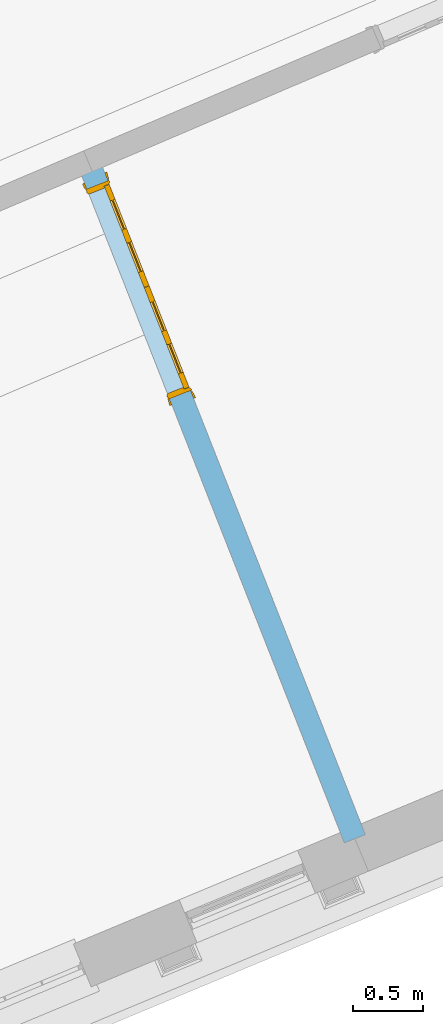
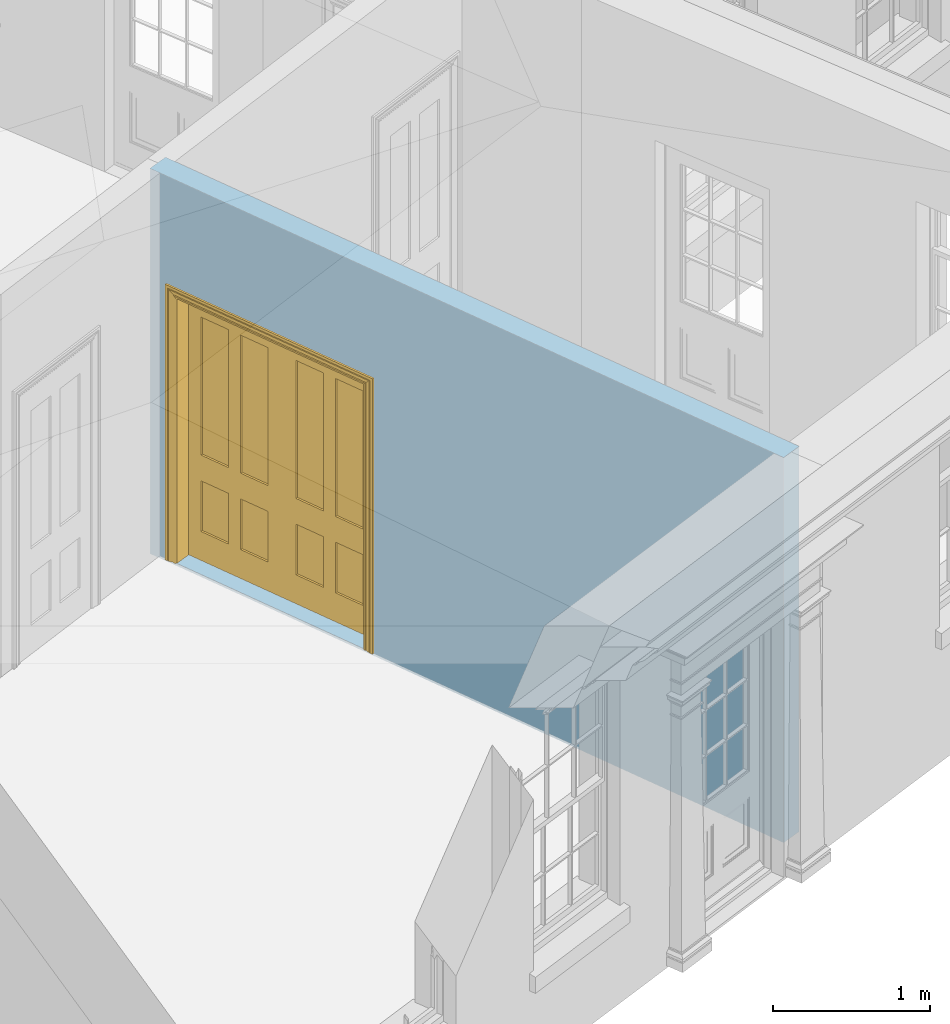
# One storey, part 6 of 19: 1 door, 1 opening, plus 1 element that does not belong to this part.
"""IFC2X3 building model written with IfcOpenShell, lengths in metres."""

from ifc_helpers import new_model, si_unit, frame, origin, place, context, subcontext, project, spatial, polyline, outline, extrude, faceted_brep, material, layer, layer_set, layer_usage, element, fill, save


model = new_model("IFC2X3")

# Units and contexts
model_context = context("Model", 3, world=origin())
body_context = subcontext(model_context, "Body", "Model", "MODEL_VIEW")
ifc_project = project(units=[si_unit("PLANEANGLEUNIT", "RADIAN"), si_unit("MASSUNIT", "GRAM", prefix="KILO"), si_unit("FORCEUNIT", "NEWTON", prefix="KILO"), si_unit("LENGTHUNIT", "METRE")], contexts=[model_context])

# Site, building, storey
site_placement = place(None, origin())
site = spatial("IfcSite", under=ifc_project, at=site_placement, CompositionType="ELEMENT")
building_placement = place(None, origin())
building = spatial("IfcBuilding", under=site, at=building_placement, Name="Building plot-0", CompositionType="ELEMENT")
storey_placement = place(None, origin())
storey = spatial("IfcBuildingStorey", under=building, at=storey_placement, Name="Floor 0", CompositionType="ELEMENT", Elevation=0.0)

# Wall, opening, door
ifc_material = material(Name="Masonry")
ifc_layer = layer(ifc_material, 0.16, ventilated=False)
ifc_layer_set = layer_set([ifc_layer], Name="My Wall")
ifc_layer_usage = layer_usage(ifc_layer_set, "AXIS2", "NEGATIVE", 0.08)
wall_placement = place(storey_placement, origin())
wall = element("IfcWallStandardCase", 1, at=wall_placement, inside=storey, material=ifc_layer_usage, Name="interior", context=body_context, shape_type="SweptSolid", body=[
    extrude(outline(polyline([(19.3861020160304, 27.3528276448736), (19.2372305853062, 27.294199178118), (21.1300433248854, 22.487903598045), (21.2789147556096, 22.5465320648006), (19.3861020160304, 27.3528276448736)])), origin(), (0.0, 0.0, 1.0), 3.0),
])
opening_placement = place(storey_placement, frame((0.0, 0.0, 0.02)))
opening = element("IfcOpeningElement", 2, at=opening_placement, cuts=wall, Name="Opening", ObjectType="Opening", context=body_context, shape_type="SweptSolid", body=[
    extrude(outline(polyline([(19.3031876104063, 27.1267188185532), (19.889472277963, 25.6380045113109), (20.0383437086872, 25.6966329780665), (19.4520590411305, 27.1853472853089), (19.3031876104063, 27.1267188185532)])), origin(), (0.0, 0.0, 1.0), 2.1),
])
door_placement = place(storey_placement, frame((19.3776233257684, 27.156033051931, 0.02), z_axis=(0.0, 0.0, 1.0), x_axis=(0.586284667556651, -1.48871430724233, 0.0)))
door = element("IfcDoor", 3, at=door_placement, inside=storey, Name="kitchen living inside door", OverallHeight=2.1, OverallWidth=1.6, context=body_context, shape_type="Brep", held_by="IfcProductRepresentation", body=[
    faceted_brep([(0.14, 0.057, 1.895), (0.14, 0.057, 0.82), (0.363, 0.057, 0.82), (0.363, 0.057, 1.895), (0.14, 0.042, 1.895), (0.14, 0.042, 0.82), (0.363, 0.042, 0.82), (0.363, 0.042, 1.895), (0.027, 0.042, 1.895), (0.027, 0.042, 0.82), (0.363, 0.042, 0.62), (0.14, 0.042, 0.62), (0.463, 0.042, 0.82), (0.463, 0.042, 1.895), (0.363, 0.042, 2.073), (0.14, 0.042, 2.073), (0.027, 0.042, 2.073), (0.027, 0.08, 1.895), (0.027, 0.08, 0.82), (0.027, 0.042, 0.62), (0.463, 0.042, 0.62), (0.14, 0.057, 0.62), (0.363, 0.057, 0.62), (0.463, 0.057, 0.82), (0.463, 0.057, 1.895), (0.463, 0.042, 2.073), (0.14, 0.08, 2.073), (0.363, 0.08, 2.073), (0.027, 0.08, 2.073), (0.14, 0.08, 1.895), (0.14, 0.08, 0.82), (0.027, 0.08, 0.62), (0.027, 0.042, 0.225), (0.14, 0.042, 0.225), (0.363, 0.042, 0.225), (0.463, 0.042, 0.225), (0.686, 0.042, 0.62), (0.686, 0.042, 0.82), (0.14, 0.057, 0.225), (0.363, 0.057, 0.225), (0.686, 0.057, 0.82), (0.686, 0.057, 1.895), (0.686, 0.042, 1.895), (0.686, 0.042, 2.073), (0.463, 0.08, 2.073), (0.363, 0.08, 1.895), (0.14, 0.065, 1.895), (0.14, 0.065, 0.82), (0.14, 0.08, 0.62), (0.027, 0.08, 0.225), (0.027, 0.042, 0.0), (0.14, 0.042, 0.0), (0.363, 0.042, 0.0), (0.463, 0.042, 0.0), (0.463, 0.057, 0.225), (0.463, 0.057, 0.62), (0.686, 0.057, 0.62), (0.799, 0.042, 0.62), (0.799, 0.042, 0.82), (0.799, 0.042, 1.895), (0.799, 0.042, 2.073), (0.686, 0.08, 2.073), (0.463, 0.08, 1.895), (0.363, 0.065, 1.895), (0.363, 0.065, 0.82), (0.363, 0.08, 0.82), (0.363, 0.08, 0.62), (0.14, 0.08, 0.225), (0.027, 0.08, 0.0), (0.14, 0.08, 0.0), (0.363, 0.08, 0.0), (0.463, 0.08, 0.0), (0.686, 0.042, 0.0), (0.686, 0.042, 0.225), (0.686, 0.057, 0.225), (0.799, 0.042, 0.225), (0.799, 0.08, 0.62), (0.799, 0.08, 0.82), (0.799, 0.08, 1.895), (0.799, 0.08, 2.073), (0.686, 0.08, 1.895), (0.463, 0.08, 0.82), (0.463, 0.08, 0.62), (0.363, 0.065, 0.62), (0.14, 0.065, 0.62), (0.14, 0.065, 0.225), (0.363, 0.08, 0.225), (0.463, 0.08, 0.225), (0.686, 0.08, 0.0), (0.799, 0.042, 0.0), (0.799, 0.08, 0.225), (0.686, 0.08, 0.62), (0.686, 0.08, 0.82), (0.686, 0.065, 1.895), (0.463, 0.065, 1.895), (0.463, 0.065, 0.82), (0.363, 0.065, 0.225), (0.686, 0.08, 0.225), (0.799, 0.08, 0.0), (0.686, 0.065, 0.82), (0.463, 0.065, 0.62), (0.463, 0.065, 0.225), (0.686, 0.065, 0.62), (0.686, 0.065, 0.225), (1.46, 0.08, 1.895), (1.237, 0.08, 1.895), (1.237, 0.08, 2.073), (1.46, 0.08, 2.073), (1.46, 0.065, 1.895), (1.237, 0.065, 1.895), (1.137, 0.08, 1.895), (1.137, 0.08, 2.073), (1.237, 0.042, 2.073), (1.46, 0.042, 2.073), (1.573, 0.08, 1.895), (1.573, 0.08, 2.073), (1.46, 0.08, 0.82), (1.46, 0.065, 0.82), (1.237, 0.065, 0.82), (1.237, 0.08, 0.82), (1.137, 0.08, 0.82), (0.914, 0.08, 2.073), (0.914, 0.08, 1.895), (1.137, 0.042, 2.073), (1.237, 0.042, 1.895), (1.46, 0.042, 1.895), (1.573, 0.042, 2.073), (1.573, 0.08, 0.82), (1.573, 0.042, 1.895), (1.237, 0.08, 0.62), (1.137, 0.08, 0.62), (1.137, 0.065, 0.82), (1.137, 0.065, 1.895), (0.914, 0.042, 2.073), (0.914, 0.065, 1.895), (0.801, 0.08, 2.073), (0.801, 0.08, 1.895), (1.137, 0.042, 1.895), (1.237, 0.057, 1.895), (1.46, 0.057, 1.895), (1.573, 0.042, 0.82), (1.573, 0.08, 0.62), (1.46, 0.08, 0.62), (1.237, 0.08, 0.225), (1.137, 0.08, 0.225), (0.914, 0.08, 0.82), (0.914, 0.08, 0.62), (0.914, 0.065, 0.82), (0.801, 0.042, 2.073), (0.914, 0.042, 1.895), (0.801, 0.08, 0.82), (0.801, 0.042, 1.895), (1.137, 0.042, 0.82), (1.237, 0.042, 0.82), (1.237, 0.057, 0.82), (1.46, 0.057, 0.82), (1.46, 0.042, 0.82), (1.573, 0.042, 0.62), (1.573, 0.08, 0.225), (1.46, 0.08, 0.225), (1.46, 0.065, 0.62), (1.237, 0.065, 0.62), (1.237, 0.08, 0.0), (1.137, 0.08, 0.0), (1.137, 0.065, 0.225), (1.137, 0.065, 0.62), (1.237, 0.065, 0.225), (0.914, 0.065, 0.62), (0.801, 0.08, 0.62), (0.914, 0.057, 1.895), (1.137, 0.057, 1.895), (0.801, 0.042, 0.82), (1.137, 0.042, 0.62), (1.237, 0.042, 0.62), (1.137, 0.057, 0.82), (1.46, 0.042, 0.62), (1.573, 0.042, 0.225), (1.573, 0.08, 0.0), (1.46, 0.08, 0.0), (1.46, 0.065, 0.225), (1.237, 0.042, 0.0), (1.137, 0.042, 0.0), (0.914, 0.08, 0.225), (0.914, 0.08, 0.0), (0.914, 0.065, 0.225), (0.801, 0.08, 0.225), (0.801, 0.042, 0.62), (0.914, 0.042, 0.82), (0.914, 0.057, 0.82), (1.137, 0.042, 0.225), (1.237, 0.042, 0.225), (0.914, 0.042, 0.62), (1.46, 0.042, 0.225), (1.573, 0.042, 0.0), (1.46, 0.042, 0.0), (0.914, 0.042, 0.0), (0.801, 0.08, 0.0), (0.801, 0.042, 0.225), (1.237, 0.057, 0.225), (1.237, 0.057, 0.62), (1.137, 0.057, 0.62), (1.137, 0.057, 0.225), (1.46, 0.057, 0.62), (0.914, 0.057, 0.62), (1.46, 0.057, 0.225), (0.914, 0.042, 0.225), (0.801, 0.042, 0.0), (0.914, 0.057, 0.225), (0.02, 0.085, 0.0), (0.005, 0.09, 0.0), (0.005, 0.09, 2.095), (0.02, 0.085, 2.08), (0.02, 0.08, 0.0), (0.0, 0.085, 0.0), (0.0, 0.085, 2.1), (1.595, 0.09, 2.095), (1.58, 0.085, 2.08), (0.02, 0.08, 2.08), (0.0, 0.08, 0.0), (-0.032, 0.095, 0.0), (-0.032, 0.095, 2.132), (1.6, 0.085, 2.1), (1.595, 0.09, 0.0), (1.58, 0.085, 0.0), (1.58, 0.08, 2.08), (0.025, 0.08, 0.0), (0.025, 0.08, 2.075), (-0.04, 0.09, 0.0), (0.025, 0.04, 0.0), (0.0, -0.08, 0.0), (-0.04, 0.09, 2.14), (1.632, 0.095, 2.132), (1.6, 0.085, 0.0), (1.58, 0.08, 0.0), (1.575, 0.08, 2.075), (0.025, 0.04, 2.075), (-0.06, 0.08, 0.0), (0.035, -0.08, 0.0), (0.0, -0.08, 2.1), (0.0, 0.08, 2.1), (-0.04, 0.095, 0.0), (-0.04, 0.095, 2.14), (1.64, 0.09, 2.14), (1.632, 0.095, 0.0), (1.6, 0.08, 0.0), (1.575, 0.08, 0.0), (1.575, 0.04, 2.075), (0.04, 0.04, 0.0), (0.04, 0.04, 2.06), (-0.06, 0.095, 0.0), (-0.06, 0.08, 2.16), (0.015, -0.085, 0.0), (0.04, -0.08, 0.0), (-0.045, -0.08, 2.145), (-0.045, -0.08, 0.0), (1.6, -0.08, 2.1), (1.6, 0.08, 2.1), (-0.06, 0.095, 2.16), (1.64, 0.095, 2.14), (1.64, 0.09, 0.0), (1.6, -0.08, 0.0), (1.575, 0.04, 0.0), (1.56, 0.04, 2.06), (0.04, -0.08, 2.06), (1.66, 0.08, 2.16), (-0.017, -0.095, 0.0), (-0.025, -0.09, 0.0), (0.02, -0.09, 0.0), (0.035, -0.085, 0.0), (0.035, -0.08, 2.065), (1.645, -0.08, 2.145), (-0.045, -0.095, 2.145), (-0.045, -0.095, 0.0), (1.66, 0.095, 2.16), (1.64, 0.095, 0.0), (1.66, 0.08, 0.0), (1.565, -0.08, 0.0), (1.56, 0.04, 0.0), (1.56, -0.08, 2.06), (-0.017, -0.095, 2.117), (-0.025, -0.09, 2.125), (0.015, -0.085, 2.085), (0.02, -0.09, 2.08), (0.035, -0.085, 2.065), (1.565, -0.08, 2.065), (1.645, -0.08, 0.0), (1.645, -0.095, 2.145), (-0.025, -0.095, 0.0), (1.66, 0.095, 0.0), (1.585, -0.085, 0.0), (1.56, -0.08, 0.0), (1.617, -0.095, 2.117), (1.625, -0.09, 2.125), (-0.025, -0.095, 2.125), (1.585, -0.085, 2.085), (1.58, -0.09, 2.08), (1.565, -0.085, 2.065), (1.625, -0.09, 0.0), (1.645, -0.095, 0.0), (1.625, -0.095, 2.125), (1.617, -0.095, 0.0), (1.565, -0.085, 0.0), (1.58, -0.09, 0.0), (1.625, -0.095, 0.0)], [[[0, 1, 2, 3]], [[1, 0, 4, 5]], [[2, 1, 5, 6]], [[6, 7, 3, 2]], [[7, 4, 0, 3]], [[4, 8, 9, 5]], [[10, 6, 5, 11]], [[6, 12, 13, 7]], [[14, 15, 4, 7]], [[15, 16, 8, 4]], [[9, 8, 17, 18]], [[5, 9, 19, 11]], [[10, 20, 12, 6]], [[10, 11, 21, 22]], [[13, 12, 23, 24]], [[7, 13, 25, 14]], [[26, 15, 14, 27]], [[28, 16, 15, 26]], [[8, 16, 28, 17]], [[17, 29, 30, 18]], [[18, 31, 19, 9]], [[11, 19, 32, 33]], [[34, 35, 20, 10]], [[20, 36, 37, 12]], [[11, 33, 38, 21]], [[39, 22, 21, 38]], [[34, 10, 22, 39]], [[12, 37, 40, 23]], [[24, 23, 40, 41]], [[42, 13, 24, 41]], [[13, 42, 43, 25]], [[14, 25, 44, 27]], [[26, 27, 45, 29]], [[28, 26, 29, 17]], [[30, 29, 46, 47]], [[18, 30, 48, 31]], [[31, 49, 32, 19]], [[33, 32, 50, 51]], [[52, 53, 35, 34]], [[20, 35, 54, 55]], [[36, 20, 55, 56]], [[36, 57, 58, 37]], [[33, 34, 39, 38]], [[37, 42, 41, 40]], [[42, 59, 60, 43]], [[44, 25, 43, 61]], [[62, 45, 27, 44]], [[29, 45, 63, 46]], [[46, 63, 64, 47]], [[65, 30, 47, 64]], [[30, 65, 66, 48]], [[31, 48, 67, 49]], [[68, 50, 32, 49]], [[68, 69, 51, 50]], [[34, 33, 51, 52]], [[53, 52, 70, 71]], [[53, 72, 73, 35]], [[35, 73, 74, 54]], [[55, 54, 74, 56]], [[73, 36, 56, 74]], [[73, 75, 57, 36]], [[57, 76, 77, 58]], [[37, 58, 59, 42]], [[78, 79, 60, 59]], [[60, 79, 61, 43]], [[80, 62, 44, 61]], [[81, 65, 45, 62]], [[45, 65, 64, 63]], [[82, 66, 65, 81]], [[48, 66, 83, 84]], [[67, 48, 84, 85]], [[49, 67, 69, 68]], [[52, 51, 69, 70]], [[71, 70, 86, 87]], [[72, 53, 71, 88]], [[72, 89, 75, 73]], [[75, 90, 76, 57]], [[76, 91, 92, 77]], [[78, 59, 58, 77]], [[78, 80, 61, 79]], [[62, 80, 93, 94]], [[81, 62, 94, 95]], [[87, 86, 66, 82]], [[91, 82, 81, 92]], [[66, 86, 96, 83]], [[84, 83, 96, 85]], [[86, 67, 85, 96]], [[67, 86, 70, 69]], [[88, 71, 87, 97]], [[89, 72, 88, 98]], [[89, 98, 90, 75]], [[90, 97, 91, 76]], [[80, 78, 77, 92]], [[80, 92, 99, 93]], [[99, 95, 94, 93]], [[92, 81, 95, 99]], [[87, 82, 100, 101]], [[82, 91, 102, 100]], [[97, 87, 101, 103]], [[98, 88, 97, 90]], [[91, 97, 103, 102]], [[103, 101, 100, 102]], [[104, 105, 106, 107]], [[105, 104, 108, 109]], [[105, 110, 111, 106]], [[106, 112, 113, 107]], [[114, 104, 107, 115]], [[104, 116, 117, 108]], [[117, 118, 109, 108]], [[119, 105, 109, 118]], [[119, 120, 110, 105]], [[121, 111, 110, 122]], [[123, 112, 106, 111]], [[124, 125, 113, 112]], [[126, 115, 107, 113]], [[104, 114, 127, 116]], [[114, 115, 126, 128]], [[116, 119, 118, 117]], [[129, 130, 120, 119]], [[110, 120, 131, 132]], [[121, 133, 123, 111]], [[122, 110, 132, 134]], [[135, 121, 122, 136]], [[137, 124, 112, 123]], [[125, 124, 138, 139]], [[125, 128, 126, 113]], [[114, 128, 140, 127]], [[141, 142, 116, 127]], [[142, 129, 119, 116]], [[143, 144, 130, 129]], [[145, 120, 130, 146]], [[120, 145, 147, 131]], [[134, 132, 131, 147]], [[135, 148, 133, 121]], [[123, 133, 149, 137]], [[145, 122, 134, 147]], [[136, 122, 145, 150]], [[151, 148, 135, 136]], [[152, 153, 124, 137]], [[124, 153, 154, 138]], [[138, 154, 155, 139]], [[156, 125, 139, 155]], [[156, 140, 128, 125]], [[157, 141, 127, 140]], [[158, 159, 142, 141]], [[129, 142, 160, 161]], [[162, 163, 144, 143]], [[130, 144, 164, 165]], [[143, 129, 161, 166]], [[146, 130, 165, 167]], [[150, 145, 146, 168]], [[133, 148, 151, 149]], [[137, 149, 169, 170]], [[171, 151, 136, 150]], [[172, 173, 153, 152]], [[152, 137, 170, 174]], [[153, 156, 155, 154]], [[175, 157, 140, 156]], [[176, 158, 141, 157]], [[177, 178, 159, 158]], [[142, 159, 179, 160]], [[179, 166, 161, 160]], [[180, 181, 163, 162]], [[182, 144, 163, 183]], [[178, 162, 143, 159]], [[144, 182, 184, 164]], [[167, 165, 164, 184]], [[159, 143, 166, 179]], [[182, 146, 167, 184]], [[168, 146, 182, 185]], [[150, 168, 186, 171]], [[149, 151, 171, 187]], [[149, 187, 188, 169]], [[169, 188, 174, 170]], [[189, 190, 173, 172]], [[173, 175, 156, 153]], [[172, 152, 187, 191]], [[187, 152, 174, 188]], [[192, 176, 157, 175]], [[193, 177, 158, 176]], [[193, 194, 178, 177]], [[181, 180, 190, 189]], [[181, 195, 183, 163]], [[194, 180, 162, 178]], [[185, 182, 183, 196]], [[168, 185, 197, 186]], [[187, 171, 186, 191]], [[173, 190, 198, 199]], [[189, 172, 200, 201]], [[175, 173, 199, 202]], [[172, 191, 203, 200]], [[194, 193, 176, 192]], [[192, 175, 202, 204]], [[180, 194, 192, 190]], [[189, 205, 195, 181]], [[196, 183, 195, 206]], [[196, 206, 197, 185]], [[191, 186, 197, 205]], [[190, 192, 204, 198]], [[199, 198, 204, 202]], [[201, 200, 203, 207]], [[205, 189, 201, 207]], [[191, 205, 207, 203]], [[205, 197, 206, 195]], [[208, 209, 210, 211]], [[208, 212, 213, 209]], [[209, 213, 214, 210]], [[211, 210, 215, 216]], [[211, 217, 212, 208]], [[218, 213, 212]], [[213, 219, 220, 214]], [[210, 214, 221, 215]], [[216, 215, 222, 223]], [[217, 211, 216, 224]], [[225, 212, 217, 226]], [[219, 213, 218, 227]], [[218, 212, 228, 229]], [[219, 227, 230, 220]], [[214, 220, 231, 221]], [[215, 221, 232, 222]], [[222, 232, 233, 223]], [[224, 216, 223, 233]], [[226, 217, 224, 234]], [[225, 228, 212]], [[235, 228, 225, 226]], [[236, 227, 218]], [[237, 229, 228]], [[229, 238, 239, 218]], [[227, 240, 241, 230]], [[220, 230, 242, 231]], [[221, 231, 243, 232]], [[244, 233, 232]], [[234, 224, 233, 245]], [[246, 235, 226, 234]], [[247, 228, 235, 248]], [[240, 227, 236, 249]], [[239, 250, 236, 218]], [[251, 229, 237]], [[252, 237, 228, 247]], [[253, 238, 229, 254]], [[238, 255, 256, 239]], [[241, 240, 257]], [[230, 241, 258, 242]], [[231, 242, 259, 243]], [[259, 244, 232, 243]], [[260, 261, 233, 244]], [[245, 233, 261]], [[261, 246, 234, 245]], [[248, 235, 246, 262]], [[248, 263, 252, 247]], [[250, 257, 249, 236]], [[240, 249, 257]], [[256, 264, 250, 239]], [[265, 266, 229, 251]], [[267, 251, 237, 268]], [[263, 269, 237, 252]], [[270, 255, 238, 253]], [[229, 266, 254]], [[271, 253, 254, 272]], [[256, 255, 260, 244]], [[273, 241, 257]], [[273, 258, 241]], [[242, 258, 274, 259]], [[275, 244, 259]], [[260, 276, 261]], [[261, 277, 262, 246]], [[262, 278, 263, 248]], [[264, 273, 257, 250]], [[244, 275, 264, 256]], [[266, 265, 279, 280]], [[265, 251, 281, 279]], [[251, 267, 282, 281]], [[269, 283, 268, 237]], [[267, 268, 283, 282]], [[278, 284, 269, 263]], [[285, 260, 255, 270]], [[286, 270, 253, 271]], [[272, 254, 266, 287]], [[271, 272, 287]], [[273, 274, 258]], [[288, 275, 259, 274]], [[276, 260, 289]], [[277, 261, 276, 290]], [[278, 262, 277, 290]], [[275, 288, 273, 264]], [[280, 279, 291, 292]], [[287, 266, 280, 293]], [[279, 281, 294, 291]], [[281, 282, 295, 294]], [[284, 296, 283, 269]], [[282, 283, 296, 295]], [[290, 276, 284, 278]], [[285, 297, 260]], [[298, 285, 270, 286]], [[299, 286, 271]], [[271, 287, 293]], [[273, 288, 274]], [[300, 289, 260, 297]], [[301, 276, 289, 302]], [[292, 291, 300, 297]], [[293, 280, 292, 299]], [[291, 294, 289, 300]], [[294, 295, 302, 289]], [[296, 284, 276, 301]], [[295, 296, 301, 302]], [[303, 297, 285, 298]], [[299, 298, 286]], [[271, 293, 299]], [[299, 292, 297, 303]], [[299, 303, 298]]]),
])
fill(opening, door)

save(model, "model.ifc")
